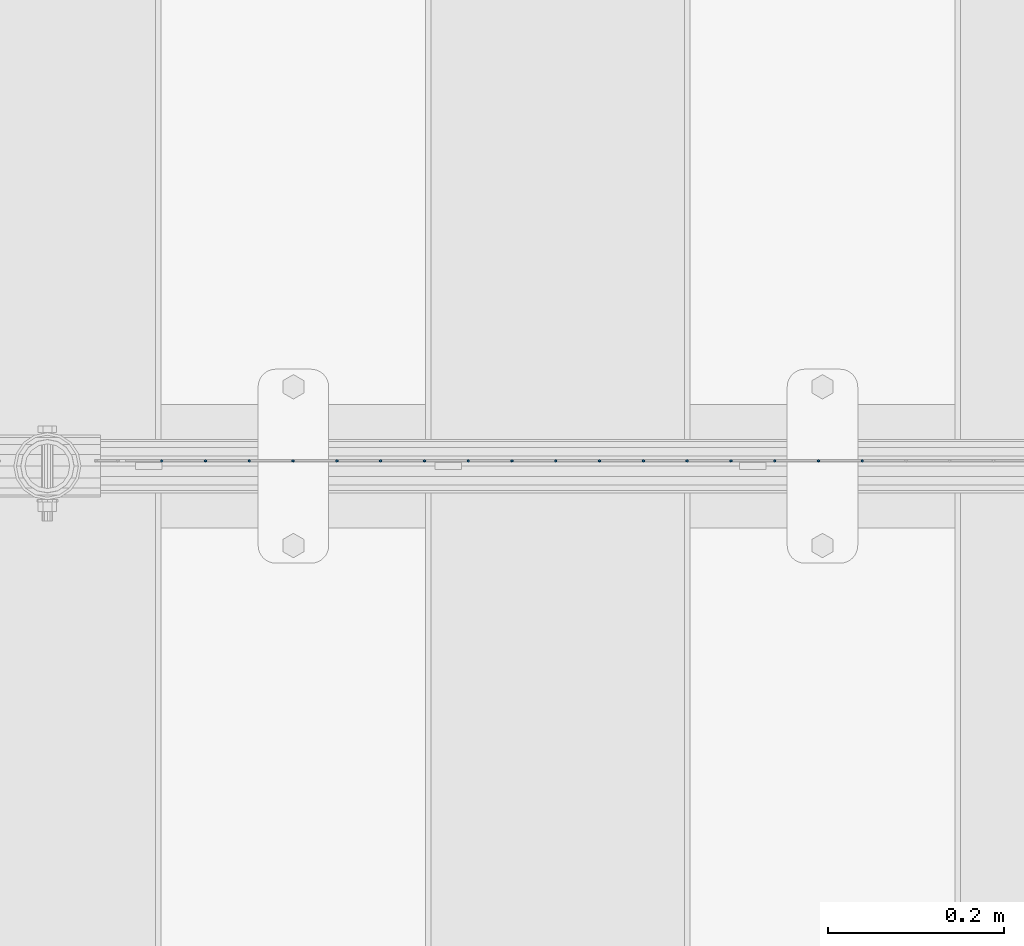
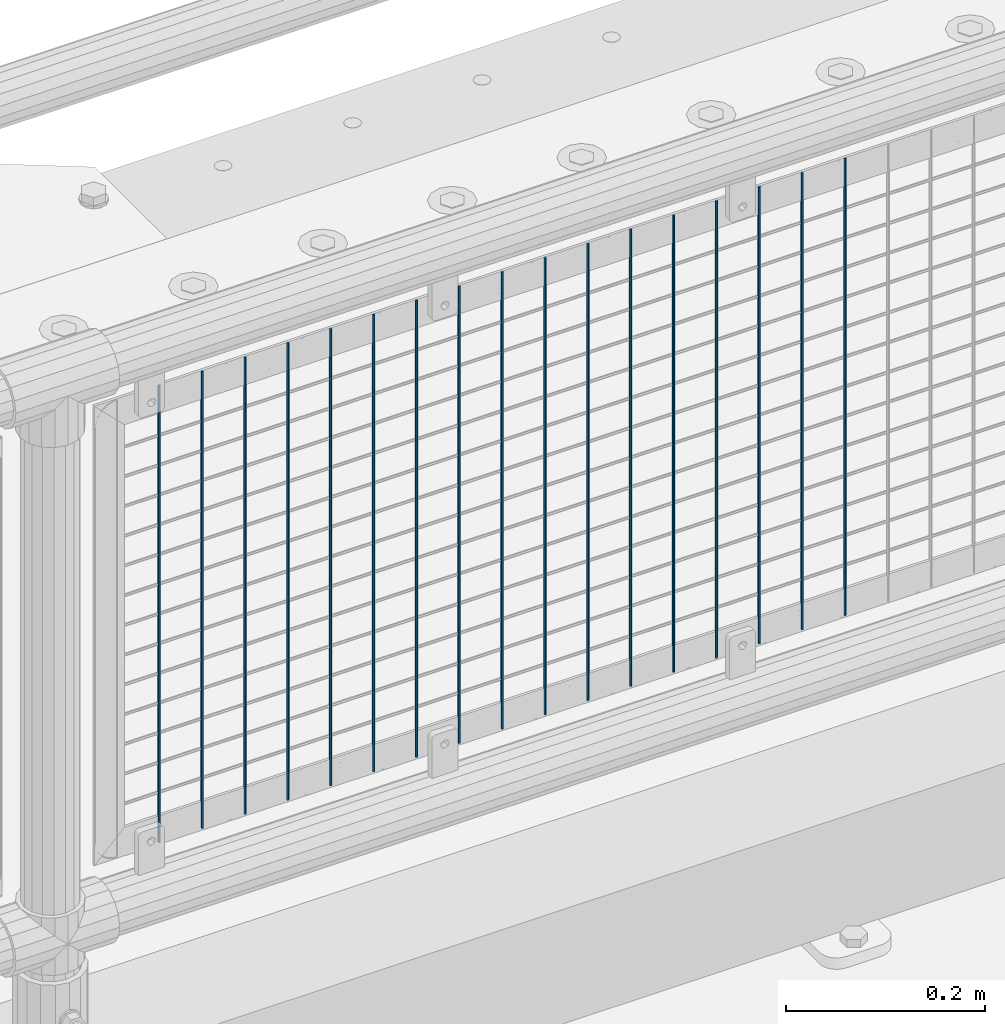
# One storey, part 68 of 208: 17 columns.
"""IFC2X3 building model written with IfcOpenShell, lengths in millimetres."""

from ifc_helpers import new_model, si_unit, frame, origin_with_axes, place, context, subcontext, project, spatial, faceted_brep, material, type_object, element, save


model = new_model("IFC2X3")

# Units and contexts
model_context = context("Model", 3, precision=1e-05, world=origin_with_axes())
body_context = subcontext(model_context, "Body", "Model", "MODEL_VIEW")
ifc_project = project(units=[si_unit("LENGTHUNIT", "METRE", prefix="MILLI"), si_unit("AREAUNIT", "SQUARE_METRE"), si_unit("VOLUMEUNIT", "CUBIC_METRE"), si_unit("MASSUNIT", "GRAM", prefix="KILO"), si_unit("TIMEUNIT", "SECOND"), si_unit("PLANEANGLEUNIT", "RADIAN"), si_unit("SOLIDANGLEUNIT", "STERADIAN"), si_unit("THERMODYNAMICTEMPERATUREUNIT", "DEGREE_CELSIUS"), si_unit("LUMINOUSINTENSITYUNIT", "LUMEN")], contexts=[model_context])

# Site, building, storey
site_placement = place(None, origin_with_axes())
site = spatial("IfcSite", under=ifc_project, at=site_placement, CompositionType="ELEMENT")
building_placement = place(site_placement, origin_with_axes())
building = spatial("IfcBuilding", under=site, at=building_placement, Name="Standard", CompositionType="ELEMENT")
storey_placement = place(building_placement, origin_with_axes())
storey = spatial("IfcBuildingStorey", under=building, at=storey_placement, Name="Undefined", CompositionType="ELEMENT", Elevation=0.0)

# Columns
ifc_material = material(Name="Misc_Undefined")
column_type = type_object("IfcColumnType", Name="D3", PredefinedType="NOTDEFINED")
for number, where, z_axis, x_axis in (
    (1, (-34504.865, 4670.5, 353.020000000002), (-1.0, 0.0, 0.0), (0.0, 0.0, 1.0)),
    (2, (-34554.52, 4670.5, 353.020000000002), (-1.0, 0.0, 0.0), (0.0, 0.0, 1.0)),
    (3, (-34604.175, 4670.5, 353.020000000002), (-1.0, 0.0, 0.0), (0.0, 0.0, 1.0)),
    (4, (-34653.83, 4670.5, 353.020000000002), (-1.0, 0.0, 0.0), (0.0, 0.0, 1.0)),
    (5, (-34703.485, 4670.5, 353.020000000002), (-1.0, 0.0, 0.0), (0.0, 0.0, 1.0)),
    (6, (-34753.14, 4670.5, 353.020000000002), (-1.0, 0.0, 0.0), (0.0, 0.0, 1.0)),
    (7, (-34802.795, 4670.5, 353.020000000002), (-1.0, 0.0, 0.0), (0.0, 0.0, 1.0)),
    (8, (-34852.45, 4670.5, 353.020000000002), (-1.0, 0.0, 0.0), (0.0, 0.0, 1.0)),
    (9, (-34902.105, 4670.5, 353.020000000002), (-1.0, 0.0, 0.0), (0.0, 0.0, 1.0)),
    (10, (-34951.76, 4670.5, 353.020000000002), (-1.0, 0.0, 0.0), (0.0, 0.0, 1.0)),
    (11, (-35001.415, 4670.5, 353.020000000002), (-1.0, 0.0, 0.0), (0.0, 0.0, 1.0)),
    (12, (-35051.07, 4670.5, 353.020000000002), (-1.0, 0.0, 0.0), (0.0, 0.0, 1.0)),
    (13, (-35100.725, 4670.5, 353.020000000002), (-1.0, 0.0, 0.0), (0.0, 0.0, 1.0)),
    (14, (-35150.38, 4670.5, 353.020000000002), (-1.0, 0.0, 0.0), (0.0, 0.0, 1.0)),
    (15, (-35200.035, 4670.5, 353.020000000002), (-1.0, 0.0, 0.0), (0.0, 0.0, 1.0)),
    (16, (-35249.6896551724, 4670.5, 353.020000000002), (-1.0, 0.0, 0.0), (0.0, 0.0, 1.0)),
    (17, (-35299.3448275862, 4670.5, 353.020000000002), (-0.999999999962839, 0.0, 8.62099999968473e-06), (8.62099999949798e-06, 0.0, 0.999999999962839)),
):
    element("IfcColumn", number, at=place(storey_placement, frame(where, z_axis=z_axis, x_axis=x_axis)), inside=storey, type_object=column_type, material=ifc_material, ObjectType="D3", context=body_context, shape_type="Brep", body=[
        faceted_brep([(0.0, -1.49999999999909, 3.63797880709171e-12), (-7.27595761418343e-12, -0.749999999999091, -1.29903810567669), (560.0, -0.75, -1.29903810567703), (560.0, -1.5, 0.0), (-3.63797880709171e-12, 0.750000000000909, -1.29903810567669), (560.0, 0.75, -1.29903810567703), (0.0, 1.50000000000182, 3.63797880709171e-12), (560.0, 1.5, 0.0), (-3.63797880709171e-12, 0.750000000000909, 1.29903810567669), (560.0, 0.75, 1.29903810567703), (-7.27595761418343e-12, -0.749999999999091, 1.29903810567669), (560.0, -0.75, 1.29903810567703)], [[[0, 1, 2, 3]], [[1, 4, 5, 2]], [[4, 6, 7, 5]], [[6, 8, 9, 7]], [[8, 10, 11, 9]], [[10, 0, 3, 11]], [[5, 7, 9, 11, 3, 2]], [[10, 8, 6, 4, 1, 0]]]),
    ])

save(model, "model.ifc")
